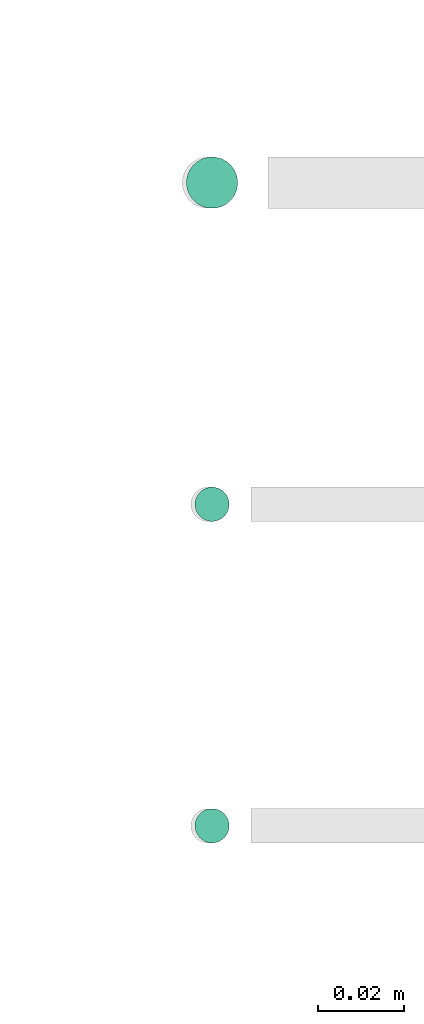
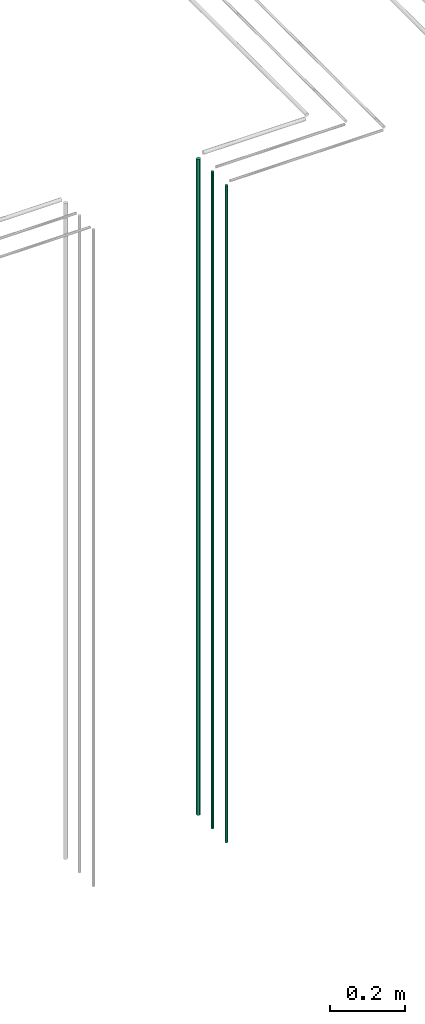
# One storey, part 45 of 331: 3 flow segments.
"""IFC2X3 building model written with IfcOpenShell, lengths in millimetres."""

from ifc_helpers import new_model, entity, si_unit, converted_unit, derived_unit, direction, frame, frame_2d, origin, origin_2d_with_axis, place, context, subcontext, project, spatial, circle, extrude, type_object, element, save


model = new_model("IFC2X3")

# Units and contexts
model_context = context("Model", 3, precision=0.01, world=origin(), true_north=direction((6.12303176911189e-17, 1.0)))
body_context = subcontext(model_context, "Body", "Model", "MODEL_VIEW")
ifc_project = project(units=[si_unit("LENGTHUNIT", "METRE", prefix="MILLI"), si_unit("AREAUNIT", "SQUARE_METRE"), si_unit("VOLUMEUNIT", "CUBIC_METRE"), converted_unit("PLANEANGLEUNIT", "DEGREE", entity("IfcRatioMeasure", 0.0174532925199433), si_unit("PLANEANGLEUNIT", "RADIAN"), dimensions=[0, 0, 0, 0, 0, 0, 0]), si_unit("MASSUNIT", "GRAM", prefix="KILO"), derived_unit("MASSDENSITYUNIT", [(si_unit("MASSUNIT", "GRAM", prefix="KILO"), 1), (si_unit("LENGTHUNIT", "METRE"), -3)]), derived_unit("MOMENTOFINERTIAUNIT", [(si_unit("LENGTHUNIT", "METRE"), 4)]), si_unit("TIMEUNIT", "SECOND"), si_unit("FREQUENCYUNIT", "HERTZ"), si_unit("THERMODYNAMICTEMPERATUREUNIT", "DEGREE_CELSIUS"), derived_unit("THERMALTRANSMITTANCEUNIT", [(si_unit("MASSUNIT", "GRAM", prefix="KILO"), 1), (si_unit("THERMODYNAMICTEMPERATUREUNIT", "KELVIN"), -1), (si_unit("TIMEUNIT", "SECOND"), -3)]), derived_unit("VOLUMETRICFLOWRATEUNIT", [(si_unit("LENGTHUNIT", "METRE"), 3), (si_unit("TIMEUNIT", "SECOND"), -1)]), derived_unit("MASSFLOWRATEUNIT", [(si_unit("MASSUNIT", "GRAM", prefix="KILO"), 1), (si_unit("TIMEUNIT", "SECOND"), -1)]), derived_unit("ROTATIONALFREQUENCYUNIT", [(si_unit("TIMEUNIT", "SECOND"), -1)]), si_unit("ELECTRICCURRENTUNIT", "AMPERE"), si_unit("ELECTRICVOLTAGEUNIT", "VOLT"), si_unit("POWERUNIT", "WATT"), si_unit("FORCEUNIT", "NEWTON", prefix="KILO"), si_unit("ILLUMINANCEUNIT", "LUX"), si_unit("LUMINOUSFLUXUNIT", "LUMEN"), si_unit("LUMINOUSINTENSITYUNIT", "CANDELA"), derived_unit("USERDEFINED", [(si_unit("MASSUNIT", "GRAM", prefix="KILO"), -1), (si_unit("LENGTHUNIT", "METRE"), -2), (si_unit("TIMEUNIT", "SECOND"), 3), (si_unit("LUMINOUSFLUXUNIT", "LUMEN"), 1)]), derived_unit("LINEARVELOCITYUNIT", [(si_unit("LENGTHUNIT", "METRE"), 1), (si_unit("TIMEUNIT", "SECOND"), -1)]), si_unit("PRESSUREUNIT", "PASCAL"), derived_unit("USERDEFINED", [(si_unit("LENGTHUNIT", "METRE"), -2), (si_unit("MASSUNIT", "GRAM", prefix="KILO"), 1), (si_unit("TIMEUNIT", "SECOND"), -2)]), derived_unit("LINEARFORCEUNIT", [(si_unit("MASSUNIT", "GRAM", prefix="KILO"), 1), (si_unit("LENGTHUNIT", "METRE"), 1), (si_unit("TIMEUNIT", "SECOND"), -2), (si_unit("LENGTHUNIT", "METRE"), -1)]), derived_unit("PLANARFORCEUNIT", [(si_unit("MASSUNIT", "GRAM", prefix="KILO"), 1), (si_unit("LENGTHUNIT", "METRE"), 1), (si_unit("TIMEUNIT", "SECOND"), -2), (si_unit("LENGTHUNIT", "METRE"), -2)])], contexts=[model_context])

# Site, building, storey
site_placement = place(None, frame((0.0, -0.00077364408347762, 0.0)))
site = spatial("IfcSite", under=ifc_project, at=site_placement, CompositionType="ELEMENT")
building_placement = place(site_placement, origin())
building = spatial("IfcBuilding", under=site, at=building_placement, CompositionType="ELEMENT")
storey_placement = place(building_placement, origin())
storey = spatial("IfcBuildingStorey", under=building, at=storey_placement, CompositionType="ELEMENT", Elevation=0.0)

# Flow segments
pipe_segment_type = type_object("IfcPipeSegmentType", PredefinedType="NOTDEFINED")
flow_segment_1_placement = place(storey_placement, frame((53569.1379388917, 1343.8934948436, 12990.0)))
element("IfcFlowSegment", 1, at=flow_segment_1_placement, inside=storey, type_object=pipe_segment_type, context=body_context, shape_type="SweptSolid", body=[
    extrude(circle(Radius=6.0, at=origin_2d_with_axis()), frame((7.59527223591454, 7.59527223591589, 0.0)), (0.0, 0.0, 1.0), 2146.00000000001),
])
flow_segment_2_placement = place(storey_placement, frame((53571.1379388917, 1270.89349484379, 12990.0)))
element("IfcFlowSegment", 2, at=flow_segment_2_placement, inside=storey, type_object=pipe_segment_type, context=body_context, shape_type="SweptSolid", body=[
    extrude(circle(Radius=4.0, at=origin_2d_with_axis()), frame((5.59527223591499, 5.5952722359158, 0.0)), (0.0, 0.0, 1.0), 2150.00000000001),
])
flow_segment_3_placement = place(storey_placement, frame((53571.1379388917, 1195.89349484366, 12990.0)))
element("IfcFlowSegment", 3, at=flow_segment_3_placement, inside=storey, type_object=pipe_segment_type, context=body_context, shape_type="SweptSolid", body=[
    extrude(circle(Radius=4.0, at=frame_2d((0.0, 1.35358391162299e-13), x_axis=(1.0, 0.0))), frame((5.59527223591499, 5.59527223591594, 0.0)), (0.0, 0.0, 1.0), 2150.00000000001),
])

save(model, "model.ifc")
